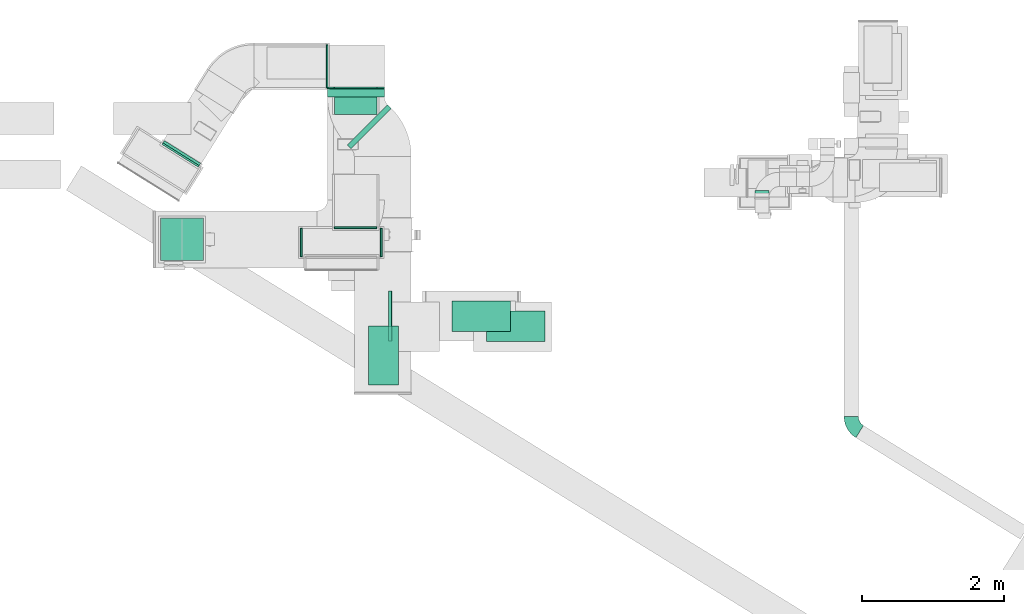
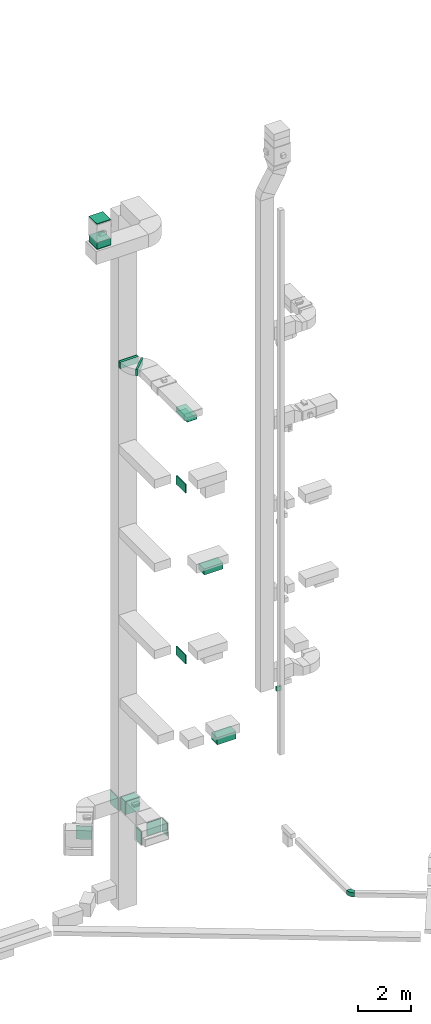
# One storey, part 10 of 29: 12 flow segments, 10 flow fittings, 1 flow terminal.
"""IFC2X3 building model written with IfcOpenShell, lengths in millimetres."""

import ifcopenshell
import ifcopenshell.guid

model = None  # the IFC model being written
_history = None  # IfcOwnerHistory: only IFC2X3 demands one
_inside = {}  # id of a spatial element -> (the spatial element, [elements in it])
_under = {}  # id of a project, library or spatial element -> (it, [spatial elements below it])
_declared = {}  # id of a project -> (the project, [libraries it declares])
_typed = {}  # id of a type object -> (the type object, [elements of that type])
_made_of = {}  # id of a material, layer set ... -> (it, [elements and type objects made of it])


def new_model(schema):
    """Start an empty IFC model of exactly this schema.

    Asked for "IFC4X3", IfcOpenShell would pick the latest addendum, in which some entities
    have other attributes; the version numbers below select the first issue.
    IFC2X3 requires an IfcOwnerHistory on every rooted entity: one is made here for all.
    """
    global model, _history
    if schema == "IFC4X3":
        model = ifcopenshell.file(schema_version=(4, 3, 0, 0))
    else:
        model = ifcopenshell.file(schema=schema)
    _inside.clear()
    _under.clear()
    _declared.clear()
    _typed.clear()
    _made_of.clear()
    _history = None
    if model.schema == "IFC2X3":
        org = make("IfcOrganization", Name="unknown")
        user = make(
            "IfcPersonAndOrganization",
            ThePerson=make("IfcPerson", FamilyName="unknown"),
            TheOrganization=org,
        )
        app = make(
            "IfcApplication",
            ApplicationDeveloper=org,
            Version="unknown",
            ApplicationFullName="unknown",
            ApplicationIdentifier="unknown",
        )
        _history = make(
            "IfcOwnerHistory",
            OwningUser=user,
            OwningApplication=app,
            ChangeAction="ADDED",
            CreationDate=0,
        )
    return model


def make(cls, **values):
    """One entity of the class cls with the attributes given. An attribute that is None is left unset."""
    return model.create_entity(
        cls, **{name: value for name, value in values.items() if value is not None}
    )


def entity(cls, *values):
    """Any entity or typed value of the class cls, its attributes in the order of the schema. None: left unset."""
    e = model.create_entity(cls)
    for i, value in enumerate(values):
        if value is not None:
            e[i] = value
    return e


def rooted(cls, **values):
    """An entity with a GlobalId (a new one), such as an element, a storey or a relation."""
    return make(cls, GlobalId=ifcopenshell.guid.new(), OwnerHistory=_history, **values)


def si_unit(unit_type, name, prefix=None):
    """IfcSIUnit, for example si_unit("LENGTHUNIT", "METRE", prefix="MILLI")."""
    return make("IfcSIUnit", UnitType=unit_type, Prefix=prefix, Name=name)


def converted_unit(unit_type, name, factor, base, dimensions=None, offset=None):
    """IfcConversionBasedUnit, such as the inch: factor (a typed value) times the base unit."""
    return make(
        "IfcConversionBasedUnit"
        if offset is None
        else "IfcConversionBasedUnitWithOffset",
        ConversionOffset=offset,
        Dimensions=None
        if dimensions is None
        else entity("IfcDimensionalExponents", *dimensions),
        UnitType=unit_type,
        Name=name,
        ConversionFactor=make(
            "IfcMeasureWithUnit", ValueComponent=factor, UnitComponent=base
        ),
    )


def derived_unit(unit_type, elements):
    """IfcDerivedUnit: a product of units, each with its exponent."""
    return make(
        "IfcDerivedUnit",
        Elements=[
            make("IfcDerivedUnitElement", Unit=unit, Exponent=power)
            for unit, power in elements
        ],
        UnitType=unit_type,
    )


def assignment(units):
    """IfcUnitAssignment: the units of a project."""
    return None if units is None else make("IfcUnitAssignment", Units=units)


def point(xyz):
    """IfcCartesianPoint."""
    return None if xyz is None else make("IfcCartesianPoint", Coordinates=xyz)


def direction(xyz):
    """IfcDirection."""
    return None if xyz is None else make("IfcDirection", DirectionRatios=xyz)


def frame(location, z_axis=None, x_axis=None):
    """IfcAxis2Placement3D, a coordinate frame: its origin and axes. An axis left out is left unset."""
    return make(
        "IfcAxis2Placement3D",
        Location=point(location),
        Axis=direction(z_axis),
        RefDirection=direction(x_axis),
    )


def frame_2d(location, x_axis=None):
    """IfcAxis2Placement2D, a coordinate frame in the plane: its origin and x axis."""
    return make(
        "IfcAxis2Placement2D", Location=point(location), RefDirection=direction(x_axis)
    )


def origin():
    """The frame at (0, 0, 0) with its axes left unset."""
    return frame((0.0, 0.0, 0.0))


def origin_2d_with_axis():
    """The frame at (0, 0) in the plane with the x axis (1, 0) written out."""
    return frame_2d((0.0, 0.0), x_axis=(1.0, 0.0))


def place(relative_to, where):
    """IfcLocalPlacement: puts the frame where relative to a parent placement (None: the world)."""
    return make(
        "IfcLocalPlacement", PlacementRelTo=relative_to, RelativePlacement=where
    )


def context(
    kind, dimensions, precision=None, world=None, true_north=None, identifier=None
):
    """IfcGeometricRepresentationContext, for example the 3D "Model" context."""
    return make(
        "IfcGeometricRepresentationContext",
        ContextIdentifier=identifier,
        ContextType=kind,
        CoordinateSpaceDimension=dimensions,
        Precision=precision,
        WorldCoordinateSystem=world,
        TrueNorth=true_north,
    )


def subcontext(parent, identifier, kind, view, scale=None):
    """IfcGeometricRepresentationSubContext, for example "Body" below "Model"."""
    return make(
        "IfcGeometricRepresentationSubContext",
        ContextIdentifier=identifier,
        ContextType=kind,
        ParentContext=parent,
        TargetScale=scale,
        TargetView=view,
    )


def project(units=None, contexts=None):
    """IfcProject with its units and contexts."""
    return rooted(
        "IfcProject",
        Name="project",
        RepresentationContexts=contexts,
        UnitsInContext=assignment(units),
    )


def spatial(cls, under=None, at=None, **own):
    """A site, building, storey or space (cls), placed at a placement, below another one or the project."""
    s = rooted(cls, ObjectPlacement=at, **own)
    if under is not None:
        _under.setdefault(under.id(), (under, []))[1].append(s)
    return s


def polyline(points):
    """IfcPolyline through the points."""
    return make("IfcPolyline", Points=[point(p) for p in points])


def circle_curve(where, radius):
    """IfcCircle in the frame where."""
    return make("IfcCircle", Position=where, Radius=radius)


def parameter(value):
    """IfcParameterValue: where a trimmed curve begins or ends, as a parameter of its basis curve."""
    return model.create_entity("IfcParameterValue", value)


def trimmed(basis, trim1, trim2, sense, master):
    """IfcTrimmedCurve: the piece of a basis curve between two trims."""
    return make(
        "IfcTrimmedCurve",
        BasisCurve=basis,
        Trim1=trim1,
        Trim2=trim2,
        SenseAgreement=sense,
        MasterRepresentation=master,
    )


def segment(curve, same_sense, transition):
    """IfcCompositeCurveSegment."""
    return make(
        "IfcCompositeCurveSegment",
        Transition=transition,
        SameSense=same_sense,
        ParentCurve=curve,
    )


def composite_curve(segments, self_intersect=None):
    """IfcCompositeCurve: segments joined end to end."""
    return make("IfcCompositeCurve", Segments=segments, SelfIntersect=self_intersect)


def profile(cls, at=None, kind="AREA", **sizes):
    """A parametric profile (cls). Its sizes go by their IFC names, for example OverallWidth=200.0."""
    return make(cls, ProfileType=kind, Position=at, **sizes)


def rectangle(**sizes):
    """IfcRectangleProfileDef."""
    return profile("IfcRectangleProfileDef", **sizes)


def outline(outer, holes=None, kind="AREA"):
    """IfcArbitraryClosedProfileDef: a profile drawn as a closed curve; with holes, ...WithVoids."""
    if holes is None:
        return make("IfcArbitraryClosedProfileDef", ProfileType=kind, OuterCurve=outer)
    return make(
        "IfcArbitraryProfileDefWithVoids",
        ProfileType=kind,
        OuterCurve=outer,
        InnerCurves=holes,
    )


def extrude(swept, where, along, depth):
    """IfcExtrudedAreaSolid: the profile swept, set in the frame where, extruded along a direction by depth."""
    return make(
        "IfcExtrudedAreaSolid",
        SweptArea=swept,
        Position=where,
        ExtrudedDirection=direction(along),
        Depth=depth,
    )


def shape(context_of_items, identifier, shape_type, items):
    """IfcShapeRepresentation: the items that make up one representation, for example the "Body"."""
    return make(
        "IfcShapeRepresentation",
        ContextOfItems=context_of_items,
        RepresentationIdentifier=identifier,
        RepresentationType=shape_type,
        Items=items,
    )


def source(mapping_origin, context_of_items, identifier, shape_type, items):
    """IfcRepresentationMap: a shape defined once, which mapped items show again and again."""
    return make(
        "IfcRepresentationMap",
        MappingOrigin=mapping_origin,
        MappedRepresentation=shape(context_of_items, identifier, shape_type, items),
    )


def transform(
    local_origin,
    x_axis=None,
    y_axis=None,
    z_axis=None,
    scale=None,
    scale2=None,
    scale3=None,
    uniform=True,
):
    """IfcCartesianTransformationOperator3D, or its non-uniform kind. x_axis, y_axis, z_axis: its Axis1, 2, 3."""
    if uniform:
        return make(
            "IfcCartesianTransformationOperator3D",
            Axis1=direction(x_axis),
            Axis2=direction(y_axis),
            LocalOrigin=point(local_origin),
            Scale=scale,
            Axis3=direction(z_axis),
        )
    return make(
        "IfcCartesianTransformationOperator3DnonUniform",
        Axis1=direction(x_axis),
        Axis2=direction(y_axis),
        LocalOrigin=point(local_origin),
        Scale=scale,
        Axis3=direction(z_axis),
        Scale2=scale2,
        Scale3=scale3,
    )


def mapped(mapping_source, mapping_target):
    """IfcMappedItem: shows the shape of a source again, moved by a transform."""
    return make(
        "IfcMappedItem", MappingSource=mapping_source, MappingTarget=mapping_target
    )


def material(Name=None, Category=None):
    """IfcMaterial."""
    return make("IfcMaterial", Name=Name, Category=Category)


def made_of(thing, what):
    """Note that an element or type object is made of a material, layer set ...; save() writes the relation."""
    if what is not None:
        _made_of.setdefault(what.id(), (what, []))[1].append(thing)
    return thing


def type_object(cls, material=None, **own):
    """A type object (cls), such as IfcWallType, which elements share."""
    return made_of(rooted(cls, **own), material)


def type_shapes(of_type, sources):
    """Give a type object the sources (RepresentationMaps) that its elements show as mapped items."""
    of_type.RepresentationMaps = sources


def element(
    cls,
    number,
    at=None,
    inside=None,
    cuts=None,
    type_object=None,
    material=None,
    context=None,
    identifier="Body",
    shape_type=None,
    held_by="IfcProductDefinitionShape",
    body=None,
    shapes=None,
    **own,
):
    """One element of the class cls, such as IfcWall. Its Tag is "e" and its number.

    at: its placement. inside: the storey or other place that contains it. cuts: it is an
    opening in that element (IfcRelVoidsElement). A single representation is given by context,
    identifier, shape_type and body (its items); several are given by shapes. held_by: the class
    of the entity that holds the representations. save() writes the other relations.
    """
    e = rooted(cls, Tag="e%d" % number, ObjectPlacement=at, **own)
    if body is not None:
        shapes = [shape(context, identifier, shape_type, body)]
    if shapes is not None:
        e.Representation = make(held_by, Representations=shapes)
    if inside is not None:
        _inside.setdefault(inside.id(), (inside, []))[1].append(e)
    if cuts is not None:
        rooted(
            "IfcRelVoidsElement", RelatingBuildingElement=cuts, RelatedOpeningElement=e
        )
    if type_object is not None:
        _typed.setdefault(type_object.id(), (type_object, []))[1].append(e)
    return made_of(e, material)


def aggregate(whole, parts):
    """IfcRelAggregates: a whole, such as a stair, and the parts it consists of."""
    return rooted("IfcRelAggregates", RelatingObject=whole, RelatedObjects=parts)


def save(model, path):
    """Write the relations noted so far, then the file.

    IfcRelAggregates (storeys below a building ...), IfcRelContainedInSpatialStructure (elements
    in a storey), IfcRelDefinesByType, IfcRelAssociatesMaterial and IfcRelDeclares: one each for
    every whole, place, type object, material and project.
    """
    for whole, parts in _under.values():
        aggregate(whole, parts)
    for where, things in _inside.values():
        rooted(
            "IfcRelContainedInSpatialStructure",
            RelatedElements=things,
            RelatingStructure=where,
        )
    for kind, things in _typed.values():
        rooted("IfcRelDefinesByType", RelatedObjects=things, RelatingType=kind)
    for what, things in _made_of.values():
        rooted("IfcRelAssociatesMaterial", RelatedObjects=things, RelatingMaterial=what)
    for by, libraries in _declared.values():
        rooted("IfcRelDeclares", RelatingContext=by, RelatedDefinitions=libraries)
    model.write(path)


model = new_model("IFC2X3")

# Units and contexts
model_context = context("Model", 3, precision=0.01, world=origin(), true_north=direction((6.12303176911189e-17, 1.0)))
body_context = subcontext(model_context, "Body", "Model", "MODEL_VIEW")
ifc_project = project(units=[si_unit("LENGTHUNIT", "METRE", prefix="MILLI"), si_unit("AREAUNIT", "SQUARE_METRE"), si_unit("VOLUMEUNIT", "CUBIC_METRE"), converted_unit("PLANEANGLEUNIT", "DEGREE", entity("IfcRatioMeasure", 0.0174532925199433), si_unit("PLANEANGLEUNIT", "RADIAN"), dimensions=[0, 0, 0, 0, 0, 0, 0]), si_unit("MASSUNIT", "GRAM", prefix="KILO"), derived_unit("MASSDENSITYUNIT", [(si_unit("MASSUNIT", "GRAM", prefix="KILO"), 1), (si_unit("LENGTHUNIT", "METRE"), -3)]), derived_unit("MOMENTOFINERTIAUNIT", [(si_unit("LENGTHUNIT", "METRE"), 4)]), si_unit("TIMEUNIT", "SECOND"), si_unit("FREQUENCYUNIT", "HERTZ"), si_unit("THERMODYNAMICTEMPERATUREUNIT", "DEGREE_CELSIUS"), derived_unit("THERMALTRANSMITTANCEUNIT", [(si_unit("MASSUNIT", "GRAM", prefix="KILO"), 1), (si_unit("THERMODYNAMICTEMPERATUREUNIT", "KELVIN"), -1), (si_unit("TIMEUNIT", "SECOND"), -3)]), derived_unit("VOLUMETRICFLOWRATEUNIT", [(si_unit("LENGTHUNIT", "METRE"), 3), (si_unit("TIMEUNIT", "SECOND"), -1)]), derived_unit("MASSFLOWRATEUNIT", [(si_unit("MASSUNIT", "GRAM", prefix="KILO"), 1), (si_unit("TIMEUNIT", "SECOND"), -1)]), derived_unit("ROTATIONALFREQUENCYUNIT", [(si_unit("TIMEUNIT", "SECOND"), -1)]), si_unit("ELECTRICCURRENTUNIT", "AMPERE"), si_unit("ELECTRICVOLTAGEUNIT", "VOLT"), si_unit("POWERUNIT", "WATT"), si_unit("FORCEUNIT", "NEWTON", prefix="KILO"), si_unit("ILLUMINANCEUNIT", "LUX"), si_unit("LUMINOUSFLUXUNIT", "LUMEN"), si_unit("LUMINOUSINTENSITYUNIT", "CANDELA"), derived_unit("USERDEFINED", [(si_unit("MASSUNIT", "GRAM", prefix="KILO"), -1), (si_unit("LENGTHUNIT", "METRE"), -2), (si_unit("TIMEUNIT", "SECOND"), 3), (si_unit("LUMINOUSFLUXUNIT", "LUMEN"), 1)]), derived_unit("LINEARVELOCITYUNIT", [(si_unit("LENGTHUNIT", "METRE"), 1), (si_unit("TIMEUNIT", "SECOND"), -1)]), si_unit("PRESSUREUNIT", "PASCAL"), derived_unit("USERDEFINED", [(si_unit("LENGTHUNIT", "METRE"), -2), (si_unit("MASSUNIT", "GRAM", prefix="KILO"), 1), (si_unit("TIMEUNIT", "SECOND"), -2)]), derived_unit("LINEARFORCEUNIT", [(si_unit("MASSUNIT", "GRAM", prefix="KILO"), 1), (si_unit("LENGTHUNIT", "METRE"), 1), (si_unit("TIMEUNIT", "SECOND"), -2), (si_unit("LENGTHUNIT", "METRE"), -1)]), derived_unit("PLANARFORCEUNIT", [(si_unit("MASSUNIT", "GRAM", prefix="KILO"), 1), (si_unit("LENGTHUNIT", "METRE"), 1), (si_unit("TIMEUNIT", "SECOND"), -2), (si_unit("LENGTHUNIT", "METRE"), -2)])], contexts=[model_context])

# Site, building, storey
site_placement = place(None, frame((0.0, -0.00077364408347762, 0.0)))
site = spatial("IfcSite", under=ifc_project, at=site_placement, CompositionType="ELEMENT")
building_placement = place(site_placement, origin())
building = spatial("IfcBuilding", under=site, at=building_placement, CompositionType="ELEMENT")
storey_placement = place(building_placement, origin())
storey = spatial("IfcBuildingStorey", under=building, at=storey_placement, CompositionType="ELEMENT", Elevation=0.0)

# Flow segments
duct_segment_type_1 = type_object("IfcDuctSegmentType", PredefinedType="NOTDEFINED")
flow_segment_1_placement = place(storey_placement, frame((10144.7174683872, 14470.8402530397, 6800.0)))
element("IfcFlowSegment", 1, at=flow_segment_1_placement, inside=storey, type_object=duct_segment_type_1, context=body_context, shape_type="SweptSolid", body=[
    extrude(rectangle(XDim=92.2080871830601, YDim=200.0, at=frame_2d((1.08357767203415e-12, -1.08713038571295e-12), x_axis=(1.0, 0.0))), frame((100.0, 46.104043591529, 0.0), z_axis=(0.0, 0.0, 1.0), x_axis=(0.0, 1.0, 0.0)), (0.0, 0.0, 1.0), 200.0),
])
flow_segment_2_placement = place(storey_placement, frame((1799.0, 13577.5681314502, 30620.0)))
element("IfcFlowSegment", 2, at=flow_segment_2_placement, inside=storey, type_object=duct_segment_type_1, context=body_context, shape_type="SweptSolid", body=[
    extrude(rectangle(XDim=600.0, YDim=600.0, at=frame_2d((-1.08002495835535e-12, 1.4210854715202e-13), x_axis=(1.0, 0.0))), frame((300.0, 300.0, 0.0), z_axis=(0.0, 0.0, 1.0), x_axis=(0.0, -1.0, 0.0)), (0.0, 0.0, 1.0), 294.999999999989),
])
flow_segment_3_placement = place(storey_placement, frame((1799.0, 13577.5681314502, 31755.0)))
element("IfcFlowSegment", 3, at=flow_segment_3_placement, inside=storey, type_object=duct_segment_type_1, context=body_context, shape_type="SweptSolid", body=[
    extrude(rectangle(XDim=599.999999999996, YDim=600.0, at=frame_2d((1.08002495835535e-12, 1.4210854715202e-13), x_axis=(1.0, 0.0))), frame((300.0, 300.0, 0.0), z_axis=(0.0, 0.0, 1.0), x_axis=(0.0, -1.0, 0.0)), (0.0, 0.0, 1.0), 30.0000000000018),
])

# Flow fittings
ifc_material_1 = material()
duct_fitting_type_1 = type_object("IfcDuctFittingType", PredefinedType="NOTDEFINED", material=ifc_material_1)
shared_shape_1 = source(origin(), body_context, "Body", "SweptSolid", [
    extrude(rectangle(XDim=24.9999999999999, YDim=400.0, at=frame_2d((-1.63424829224823e-13, 0.0), x_axis=(1.0, 0.0))), frame((12.5000000000061, 0.0, -300.0)), (0.0, 0.0, 1.0), 600.0),
])
type_shapes(duct_fitting_type_1, [shared_shape_1])
flow_fitting_1_placement = place(storey_placement, frame((3785.84688819859, 13832.5, 2800.0), z_axis=(0.0, 0.0, 1.0), x_axis=(-1.0, 0.0, 0.0)))
element("IfcFlowFitting", 4, at=flow_fitting_1_placement, inside=storey, type_object=duct_fitting_type_1, material=ifc_material_1, context=body_context, shape_type="MappedRepresentation", body=[
    mapped(shared_shape_1, transform((0.0, 0.0, 0.0), scale=1.0)),
])
flow_fitting_2_placement = place(storey_placement, frame((4885.84688819857, 13832.5, 2800.0)))
element("IfcFlowFitting", 5, at=flow_fitting_2_placement, inside=storey, type_object=duct_fitting_type_1, material=ifc_material_1, context=body_context, shape_type="MappedRepresentation", body=[
    mapped(shared_shape_1, transform((0.0, 0.0, 0.0), scale=1.0)),
])
duct_fitting_type_2 = type_object("IfcDuctFittingType", PredefinedType="NOTDEFINED", material=ifc_material_1)
shared_shape_2 = source(origin(), body_context, "Body", "SweptSolid", [
    extrude(rectangle(XDim=26.0960000000009, YDim=600.0, at=frame_2d((-4.66293670342566e-13, -1.4210854715202e-13), x_axis=(1.0, 0.0))), frame((6.95199999999999, 0.0, -300.0)), (0.0, 0.0, 1.0), 600.0),
])
type_shapes(duct_fitting_type_2, [shared_shape_2])
for number, where, z_axis, x_axis in (
    (6, (4143.33051695451, 16309.9756321925, 2785.0), (0.0, 1.0, 0.0), (-1.0, 0.0, 0.0)),
    (7, (4538.73846384672, 16009.9756321912, 2800.0), (-1.0, 0.0, 0.0), (0.0, -1.0, 0.0)),
    (8, (4538.73846384672, 14032.5, 2800.0), (0.0, 0.0, -1.0), (0.0, 1.0, 0.0)),
):
    element("IfcFlowFitting", number, at=place(storey_placement, frame(where, z_axis=z_axis, x_axis=x_axis)), inside=storey, type_object=duct_fitting_type_2, material=ifc_material_1, context=body_context, shape_type="MappedRepresentation", body=[
        mapped(shared_shape_2, transform((0.0, 0.0, 0.0), scale=1.0)),
    ])
duct_fitting_type_3 = type_object("IfcDuctFittingType", PredefinedType="NOTDEFINED", material=ifc_material_1)
shared_shape_3 = source(origin(), body_context, "Body", "SweptSolid", [
    extrude(rectangle(XDim=600.0, YDim=26.0960000000043, at=origin_2d_with_axis()), frame((6.95199999999999, 0.0, -300.0), z_axis=(0.0, 0.0, 1.0), x_axis=(0.0, -1.0, 0.0)), (0.0, 0.0, 1.0), 600.0),
])
type_shapes(duct_fitting_type_3, [shared_shape_3])
flow_fitting_3_placement = place(storey_placement, frame((2099.0, 13877.5681314502, 30600.0), z_axis=(0.0, -1.0, 0.0), x_axis=(0.0, 0.0, 1.0)))
element("IfcFlowFitting", 9, at=flow_fitting_3_placement, inside=storey, type_object=duct_fitting_type_3, material=ifc_material_1, context=body_context, shape_type="MappedRepresentation", body=[
    mapped(shared_shape_3, transform((0.0, 0.0, 0.0), scale=1.0)),
])
duct_fitting_type_4 = type_object("IfcDuctFittingType", PredefinedType="NOTDEFINED", material=ifc_material_1)
shared_shape_4 = source(origin(), body_context, "Body", "SweptSolid", [
    extrude(rectangle(XDim=26.0960000000156, YDim=300.0, at=frame_2d((-2.32702745961433e-13, -9.9475983006414e-14), x_axis=(1.0, 0.0))), frame((6.95200000000107, 0.0, -400.0)), (0.0, 0.0, 1.0), 800.0),
])
type_shapes(duct_fitting_type_4, [shared_shape_4])
flow_fitting_4_placement = place(storey_placement, frame((4543.33051695516, 16009.9756321921, 23050.0), z_axis=(-1.0, 0.0, 0.0), x_axis=(0.0, -1.0, 0.0)))
element("IfcFlowFitting", 10, at=flow_fitting_4_placement, inside=storey, type_object=duct_fitting_type_4, material=ifc_material_1, context=body_context, shape_type="MappedRepresentation", body=[
    mapped(shared_shape_4, transform((0.0, 0.0, 0.0), scale=1.0)),
])

# Flow terminal
ifc_material_2 = material()
air_terminal_type = type_object("IfcAirTerminalType", PredefinedType="NOTDEFINED", material=ifc_material_2)
shared_shape_5 = source(origin(), body_context, "Body", "SweptSolid", [
    extrude(rectangle(XDim=4.0, YDim=824.999999999999, at=origin_2d_with_axis()), frame((0.0, -2.0, -212.500000000002), z_axis=(0.0, 0.0, 1.0), x_axis=(0.0, 1.0, 0.0)), (0.0, 0.0, 1.0), 425.000000000005),
])
type_shapes(air_terminal_type, [shared_shape_5])
flow_terminal_placement = place(storey_placement, frame((4929.6617599011, 12246.981027348, 22700.0), z_axis=(1.0, 0.0, 0.0), x_axis=(0.0, 1.0, 0.0)))
element("IfcFlowTerminal", 11, at=flow_terminal_placement, inside=storey, type_object=air_terminal_type, material=ifc_material_2, context=body_context, shape_type="MappedRepresentation", body=[
    mapped(shared_shape_5, transform((0.0, 0.0, 0.0), scale=1.0)),
])

# Flow segments
duct_segment_type_2 = type_object("IfcDuctSegmentType", PredefinedType="NOTDEFINED")
flow_segment_4_placement = place(storey_placement, frame((5000.45036991614, 12449.6581969188, 18950.0)))
element("IfcFlowSegment", 12, at=flow_segment_4_placement, inside=storey, type_object=duct_segment_type_2, context=body_context, shape_type="SweptSolid", body=[
    extrude(rectangle(XDim=49.1980317029415, YDim=699.999999999999, at=frame_2d((-5.41788836017076e-13, 0.0), x_axis=(1.0, 0.0))), frame((24.5990158514702, 350.0, 0.0)), (0.0, 0.0, 1.0), 400.0),
])
flow_segment_5_placement = place(storey_placement, frame((4999.45036991614, 12449.6581969188, 11100.0)))
element("IfcFlowSegment", 13, at=flow_segment_5_placement, inside=storey, type_object=duct_segment_type_2, context=body_context, shape_type="SweptSolid", body=[
    extrude(rectangle(XDim=40.1980317029457, YDim=699.999999999999, at=frame_2d((5.40012479177676e-13, 1.08002495835535e-12), x_axis=(1.0, 0.0))), frame((20.0990158514734, 350.0, 0.0)), (0.0, 0.0, 1.0), 400.0),
])
flow_segment_6_placement = place(storey_placement, frame((5889.68731985035, 12585.1581969188, 14800.0)))
element("IfcFlowSegment", 14, at=flow_segment_6_placement, inside=storey, type_object=duct_segment_type_2, context=body_context, shape_type="SweptSolid", body=[
    extrude(rectangle(XDim=825.000000000001, YDim=425.000000000001, at=frame_2d((0.0, -1.08002495835535e-12), x_axis=(1.0, 0.0))), frame((412.5, 212.500000000002, 0.0)), (0.0, 0.0, 1.0), 279.999999999988),
])
flow_segment_7_placement = place(storey_placement, frame((6374.70564419274, 12444.6581969188, 6900.0)))
element("IfcFlowSegment", 15, at=flow_segment_7_placement, inside=storey, type_object=duct_segment_type_2, context=body_context, shape_type="SweptSolid", body=[
    extrude(rectangle(XDim=825.0, YDim=425.000000000001, at=frame_2d((5.40012479177676e-13, 1.08002495835535e-12), x_axis=(1.0, 0.0))), frame((412.500000000002, 212.500000000004, 0.0), z_axis=(0.0, 0.0, 1.0), x_axis=(-1.0, 0.0, 0.0)), (0.0, 0.0, 1.0), 329.999999999994),
])
flow_segment_8_placement = place(storey_placement, frame((4238.73846384671, 15631.3442907761, 2500.0)))
element("IfcFlowSegment", 16, at=flow_segment_8_placement, inside=storey, type_object=duct_segment_type_2, context=body_context, shape_type="SweptSolid", body=[
    extrude(rectangle(XDim=358.631341415064, YDim=600.0, at=frame_2d((0.0, 5.40012479177676e-13), x_axis=(1.0, 0.0))), frame((300.0, 179.315670707534, 0.0), z_axis=(0.0, 0.0, 1.0), x_axis=(0.0, 1.0, 0.0)), (0.0, 0.0, 1.0), 600.0),
])
flow_segment_9_placement = place(storey_placement, frame((4717.16175990109, 11834.481027348, 22700.0)))
element("IfcFlowSegment", 17, at=flow_segment_9_placement, inside=storey, type_object=duct_segment_type_2, context=body_context, shape_type="SweptSolid", body=[
    extrude(rectangle(XDim=824.999999999999, YDim=425.0, at=frame_2d((0.0, -2.70006239588838e-13), x_axis=(1.0, 0.0))), frame((212.500000000002, 412.500000000002, 0.0), z_axis=(0.0, 0.0, 1.0), x_axis=(0.0, 1.0, 0.0)), (0.0, 0.0, 1.0), 179.999999999955),
])
flow_segment_10_placement = place(storey_placement, frame((1832.29288255395, 14914.7903768052, 2485.0)))
element("IfcFlowSegment", 18, at=flow_segment_10_placement, inside=storey, type_object=duct_segment_type_2, context=body_context, shape_type="SweptSolid", body=[
    extrude(rectangle(XDim=37.4538722069301, YDim=600.000000000002, at=frame_2d((-7.46069872548105e-14, 1.13686837721616e-13), x_axis=(1.0, 0.0))), frame((264.338193032185, 174.857121806744, 0.0), z_axis=(0.0, 0.0, 1.0), x_axis=(-0.529919264328232, -0.848048096097047, 0.0)), (0.0, 0.0, 1.0), 600.0),
])
flow_segment_11_placement = place(storey_placement, frame((4421.57907482802, 15149.8573044298, 22900.0)))
element("IfcFlowSegment", 19, at=flow_segment_11_placement, inside=storey, type_object=duct_segment_type_2, context=body_context, shape_type="SweptSolid", body=[
    extrude(rectangle(XDim=76.5778291089947, YDim=800.0, at=frame_2d((1.14752651825256e-12, -3.97903932025656e-13), x_axis=(1.0, 0.0))), frame((309.917063600312, 309.917063600441, 0.0), z_axis=(0.0, 0.0, 1.0), x_axis=(-0.707106781186724, 0.707106781186371, 0.0)), (0.0, 0.0, 1.0), 300.000000000001),
])
flow_segment_12_placement = place(storey_placement, frame((4143.33051695515, 15875.7574488085, 22900.0)))
element("IfcFlowSegment", 20, at=flow_segment_12_placement, inside=storey, type_object=duct_segment_type_2, context=body_context, shape_type="SweptSolid", body=[
    extrude(rectangle(XDim=114.218183383578, YDim=800.0, at=frame_2d((2.16715534406831e-12, -5.40012479177676e-13), x_axis=(1.0, 0.0))), frame((400.0, 57.1090916918052, 0.0), z_axis=(0.0, 0.0, 1.0), x_axis=(0.0, 1.0, 0.0)), (0.0, 0.0, 1.0), 300.000000000001),
])

# Flow fittings
duct_fitting_type_5 = type_object("IfcDuctFittingType", PredefinedType="NOTDEFINED", material=ifc_material_1)
shared_shape_6 = source(origin(), body_context, "Body", "SweptSolid", [
    extrude(rectangle(XDim=825.0, YDim=26.0960000000087, at=frame_2d((-5.6843418860808e-14, 0.0), x_axis=(1.0, 0.0))), frame((6.95200000000432, 0.0, -212.5), z_axis=(0.0, 0.0, 1.0), x_axis=(0.0, -1.0, 0.0)), (0.0, 0.0, 1.0), 425.0),
])
type_shapes(duct_fitting_type_5, [shared_shape_6])
flow_fitting_5_placement = place(storey_placement, frame((4929.6617599011, 12246.981027348, 22900.0), z_axis=(-1.0, 0.0, 0.0), x_axis=(0.0, 0.0, -1.0)))
element("IfcFlowFitting", 21, at=flow_fitting_5_placement, inside=storey, type_object=duct_fitting_type_5, material=ifc_material_1, context=body_context, shape_type="MappedRepresentation", body=[
    mapped(shared_shape_6, transform((0.0, 0.0, 0.0), scale=1.0)),
])
duct_fitting_type_6 = type_object("IfcDuctFittingType", PredefinedType="NOTDEFINED", material=ifc_material_1)
shared_shape_7 = source(origin(), body_context, "Body", "SweptSolid", [
    extrude(rectangle(XDim=26.0960001864425, YDim=600.0, at=frame_2d((-4.66293670342566e-13, -1.4210854715202e-13), x_axis=(1.0, 0.0))), frame((6.95199999999943, 0.0, -300.0)), (0.0, 0.0, 1.0), 600.0),
])
type_shapes(duct_fitting_type_6, [shared_shape_7])
flow_fitting_6_placement = place(storey_placement, frame((2076.10892604789, 15056.8051941039, 2785.0), z_axis=(0.848048096097045, -0.529919264328234, 0.0), x_axis=(0.529919264328233, 0.848048096097046, 0.0)))
element("IfcFlowFitting", 22, at=flow_fitting_6_placement, inside=storey, type_object=duct_fitting_type_6, material=ifc_material_1, context=body_context, shape_type="MappedRepresentation", body=[
    mapped(shared_shape_7, transform((0.0, 0.0, 0.0), scale=1.0)),
])
duct_fitting_type_7 = type_object("IfcDuctFittingType", PredefinedType="NOTDEFINED", material=ifc_material_1)
shared_shape_8 = source(origin(), body_context, "Body", "SweptSolid", [
    extrude(outline(composite_curve([segment(polyline([(-159.310426497975, -106.347919270299), (40.6895735020247, -106.347919270299)]), True, "CONTINUOUS"), segment(trimmed(circle_curve(frame_2d((190.689573502025, -106.347919270299), x_axis=(-0.525516588016195, 0.850783354162388)), 150.0), [parameter(0.0)], [parameter(58.2969737827834)], True, "PARAMETER"), False, "CONTINUOUS"), segment(polyline([(111.862085299595, 21.2695838540601), (6.75876769635568, 191.426254686539)]), True, "CONTINUOUS"), segment(trimmed(circle_curve(frame_2d((190.689573502025, -106.347919270299), x_axis=(-0.525516588016195, 0.850783354162388)), 350.0), [parameter(0.0)], [parameter(58.2969737827834)], True, "PARAMETER"), True, "CONTINUOUS")], self_intersect=False)), frame((-33.0775318925631, 59.3104264979672, -100.0), z_axis=(0.0, 0.0, 1.0), x_axis=(-0.850783354162395, 0.525516588016197, 0.0)), (0.0, 0.0, 1.0), 200.0),
])
type_shapes(duct_fitting_type_7, [shared_shape_8])
flow_fitting_7_placement = place(storey_placement, frame((11499.830255056, 11250.4983381738, -1000.0), z_axis=(0.0, 0.0, 1.0), x_axis=(0.0, -1.0, 0.0)))
element("IfcFlowFitting", 23, at=flow_fitting_7_placement, inside=storey, type_object=duct_fitting_type_7, material=ifc_material_1, context=body_context, shape_type="MappedRepresentation", body=[
    mapped(shared_shape_8, transform((0.0, 0.0, 0.0), scale=1.0)),
])

save(model, "model.ifc")
